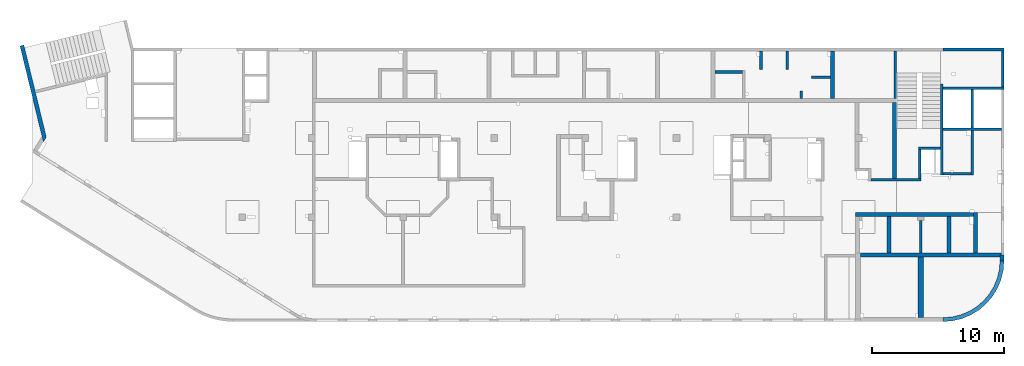
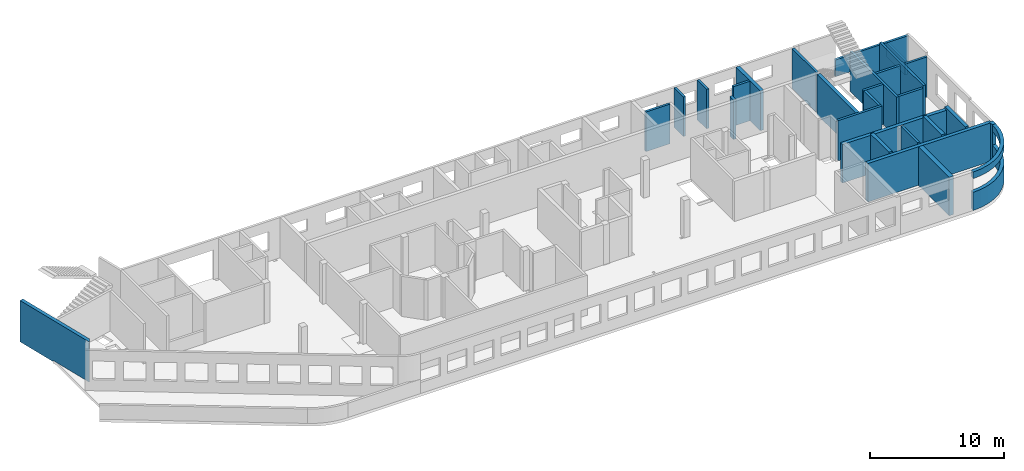
# One storey, part 5 of 10: 29 walls.
"""IFC4 building model written with IfcOpenShell, lengths in millimetres."""

from ifc_helpers import new_model, entity, si_unit, converted_unit, derived_unit, direction, frame, origin, place, context, subcontext, project, spatial, indexed_curve, outline, extrude, polygons, material, type_object, element, save


model = new_model("IFC4")

# Units and contexts
model_context = context("Model", 3, precision=0.01, world=origin(), true_north=direction((6.12303176911189e-17, 1.0)))
plan_context = context("Plan", 3, precision=0.01, world=origin(), true_north=direction((6.12303176911189e-17, 1.0)))
body_context = subcontext(model_context, "Body", "Model", "MODEL_VIEW")
ifc_project = project(units=[si_unit("LENGTHUNIT", "METRE", prefix="MILLI"), si_unit("AREAUNIT", "SQUARE_METRE"), si_unit("VOLUMEUNIT", "CUBIC_METRE"), converted_unit("PLANEANGLEUNIT", "DEGREE", entity("IfcRatioMeasure", 0.0174532925199433), si_unit("PLANEANGLEUNIT", "RADIAN"), dimensions=[0, 0, 0, 0, 0, 0, 0]), si_unit("MASSUNIT", "GRAM", prefix="KILO"), derived_unit("MASSDENSITYUNIT", [(si_unit("MASSUNIT", "GRAM", prefix="KILO"), 1), (si_unit("LENGTHUNIT", "METRE"), -3)]), derived_unit("MOMENTOFINERTIAUNIT", [(si_unit("LENGTHUNIT", "METRE"), 4)]), si_unit("TIMEUNIT", "SECOND"), si_unit("FREQUENCYUNIT", "HERTZ"), si_unit("THERMODYNAMICTEMPERATUREUNIT", "DEGREE_CELSIUS"), derived_unit("THERMALTRANSMITTANCEUNIT", [(si_unit("MASSUNIT", "GRAM", prefix="KILO"), 1), (si_unit("THERMODYNAMICTEMPERATUREUNIT", "KELVIN"), -1), (si_unit("TIMEUNIT", "SECOND"), -3)]), derived_unit("VOLUMETRICFLOWRATEUNIT", [(si_unit("LENGTHUNIT", "METRE"), 3), (si_unit("TIMEUNIT", "SECOND"), -1)]), derived_unit("MASSFLOWRATEUNIT", [(si_unit("MASSUNIT", "GRAM", prefix="KILO"), 1), (si_unit("TIMEUNIT", "SECOND"), -1)]), derived_unit("ROTATIONALFREQUENCYUNIT", [(si_unit("TIMEUNIT", "SECOND"), -1)]), si_unit("ELECTRICCURRENTUNIT", "AMPERE"), si_unit("ELECTRICVOLTAGEUNIT", "VOLT"), si_unit("POWERUNIT", "WATT"), si_unit("FORCEUNIT", "NEWTON", prefix="KILO"), si_unit("ILLUMINANCEUNIT", "LUX"), si_unit("LUMINOUSFLUXUNIT", "LUMEN"), si_unit("LUMINOUSINTENSITYUNIT", "CANDELA"), derived_unit("USERDEFINED", [(si_unit("MASSUNIT", "GRAM", prefix="KILO"), -1), (si_unit("LENGTHUNIT", "METRE"), -2), (si_unit("TIMEUNIT", "SECOND"), 3), (si_unit("LUMINOUSFLUXUNIT", "LUMEN"), 1)]), derived_unit("LINEARVELOCITYUNIT", [(si_unit("LENGTHUNIT", "METRE"), 1), (si_unit("TIMEUNIT", "SECOND"), -1)]), si_unit("PRESSUREUNIT", "PASCAL"), derived_unit("USERDEFINED", [(si_unit("LENGTHUNIT", "METRE"), -2), (si_unit("MASSUNIT", "GRAM", prefix="KILO"), 1), (si_unit("TIMEUNIT", "SECOND"), -2)]), derived_unit("LINEARFORCEUNIT", [(si_unit("MASSUNIT", "GRAM", prefix="KILO"), 1), (si_unit("LENGTHUNIT", "METRE"), 1), (si_unit("TIMEUNIT", "SECOND"), -2), (si_unit("LENGTHUNIT", "METRE"), -1)]), derived_unit("PLANARFORCEUNIT", [(si_unit("MASSUNIT", "GRAM", prefix="KILO"), 1), (si_unit("LENGTHUNIT", "METRE"), 1), (si_unit("TIMEUNIT", "SECOND"), -2), (si_unit("LENGTHUNIT", "METRE"), -2)])], contexts=[model_context, plan_context])

# Site, building, storey
site_placement = place(None, origin())
site = spatial("IfcSite", under=ifc_project, at=site_placement, CompositionType="ELEMENT")
building_placement = place(site_placement, origin())
building = spatial("IfcBuilding", under=site, at=building_placement, CompositionType="ELEMENT")
storey_placement = place(building_placement, frame((0.0, 0.0, 4200.0)))
storey = spatial("IfcBuildingStorey", under=building, at=storey_placement, Name="02", CompositionType="ELEMENT", Elevation=4200.0)

# Walls
ifc_material = material()
wall_type_1 = type_object("IfcWallType", Name=":ADSK_ 25_200", PredefinedType="STANDARD")
wall_1_placement = place(storey_placement, frame((55170.0, 20300.0, -150.0), z_axis=(0.0, 0.0, 1.0), x_axis=(0.0, -1.0, 0.0)))
element("IfcWall", 1, at=wall_1_placement, inside=storey, type_object=wall_type_1, material=ifc_material, Name=":ADSK_ 25_200", ObjectType=":ADSK_ 25_200", PredefinedType="NOTDEFINED", context=body_context, shape_type="SweptSolid", body=[
    extrude(outline(indexed_curve([(1400.00000000018, 100.000000000003), (0.0, 100.000000000003), (0.0, -100.000000000003), (1400.00000000018, -100.000000000003), (1400.00000000018, 100.000000000003)], self_intersect=False)), origin(), (0.0, 0.0, 1.0), 3600.0),
])
wall_2_placement = place(storey_placement, frame((57170.0, 20300.0, -150.0), z_axis=(0.0, 0.0, 1.0), x_axis=(0.0, -1.0, 0.0)))
element("IfcWall", 2, at=wall_2_placement, inside=storey, type_object=wall_type_1, material=ifc_material, Name=":ADSK_ 25_200", ObjectType=":ADSK_ 25_200", PredefinedType="NOTDEFINED", context=body_context, shape_type="SweptSolid", body=[
    extrude(outline(indexed_curve([(1400.00000000017, 100.000000000003), (0.0, 100.000000000003), (0.0, -100.000000000003), (1400.00000000017, -100.000000000003), (1400.00000000017, 100.000000000003)], self_intersect=False)), origin(), (0.0, 0.0, 1.0), 3600.0),
])
wall_3_placement = place(storey_placement, frame((53770.0, 18700.0, -150.0), z_axis=(0.0, 0.0, 1.0), x_axis=(-1.0, 0.0, 0.0)))
element("IfcWall", 3, at=wall_3_placement, inside=storey, type_object=wall_type_1, material=ifc_material, Name=":ADSK_ 25_200", ObjectType=":ADSK_ 25_200", PredefinedType="NOTDEFINED", context=body_context, shape_type="SweptSolid", body=[
    extrude(outline(indexed_curve([(2079.99999999999, 99.9999999999984), (-2.84965034025891e-13, 99.9999999999989), (2.84965034025891e-13, -99.9999999999989), (2080.0, -99.9999999999995), (2079.99999999999, 99.9999999999984)], self_intersect=False)), origin(), (0.0, 0.0, 1.0), 3600.0),
])
wall_4_placement = place(storey_placement, frame((58220.0, 16700.0, -150.0), z_axis=(0.0, 0.0, 1.0), x_axis=(0.0, 1.0, 0.0)))
element("IfcWall", 4, at=wall_4_placement, inside=storey, type_object=wall_type_1, material=ifc_material, Name=":ADSK_ 25_200", ObjectType=":ADSK_ 25_200", PredefinedType="NOTDEFINED", context=body_context, shape_type="SweptSolid", body=[
    extrude(outline(indexed_curve([(550.000000000001, 100.000000000003), (0.0, 100.000000000003), (0.0, -100.000000000003), (550.000000000001, -100.000000000003), (550.000000000001, 100.000000000003)], self_intersect=False)), origin(), (0.0, 0.0, 1.0), 3600.0),
])
wall_5_placement = place(storey_placement, frame((60420.0, 18300.0, -150.0), z_axis=(0.0, 0.0, 1.0), x_axis=(-1.0, 0.0, 0.0)))
element("IfcWall", 5, at=wall_5_placement, inside=storey, type_object=wall_type_1, material=ifc_material, Name=":ADSK_ 25_200", ObjectType=":ADSK_ 25_200", PredefinedType="NOTDEFINED", context=body_context, shape_type="SweptSolid", body=[
    extrude(outline(indexed_curve([(1430.0, 99.9999999999994), (-3.38034999930937e-13, 99.9999999999989), (3.38034999930937e-13, -99.9999999999989), (1430.0, -99.9999999999984), (1430.0, 99.9999999999994)], self_intersect=False)), origin(), (0.0, 0.0, 1.0), 3600.0),
])
wall_6_placement = place(storey_placement, frame((65330.0, 16700.0, -150.0), z_axis=(0.0, 0.0, 1.0), x_axis=(0.0, 1.0, 0.0)))
element("IfcWall", 6, at=wall_6_placement, inside=storey, type_object=wall_type_1, material=ifc_material, Name=":ADSK_ 25_200", ObjectType=":ADSK_ 25_200", PredefinedType="NOTDEFINED", context=body_context, shape_type="SweptSolid", body=[
    extrude(outline(indexed_curve([(3600.00000000025, 100.000000000003), (-2.40637139844095e-13, 100.000000000003), (2.40637139844095e-13, -100.000000000003), (3600.00000000025, -100.000000000003), (3600.00000000025, 100.000000000003)], self_intersect=False)), origin(), (0.0, 0.0, 1.0), 3600.0),
])
wall_7_placement = place(storey_placement, frame((68870.0, 17780.0, -150.0), z_axis=(0.0, 0.0, 1.0), x_axis=(0.0, -1.0, 0.0)))
element("IfcWall", 7, at=wall_7_placement, inside=storey, type_object=wall_type_1, material=ifc_material, Name=":ADSK_ 25_200", ObjectType=":ADSK_ 25_200", PredefinedType="NOTDEFINED", context=body_context, shape_type="SweptSolid", body=[
    extrude(outline(indexed_curve([(6894.9999999995, 100.000000000003), (0.0, 100.000000000003), (0.0, -100.000000000003), (6894.9999999995, -100.000000000003), (6894.9999999995, 100.000000000003)], self_intersect=False)), origin(), (0.0, 0.0, 1.0), 3650.0),
])
wall_8_placement = place(storey_placement, frame((68970.0, 17470.0, -150.0)))
element("IfcWall", 8, at=wall_8_placement, inside=storey, type_object=wall_type_1, material=ifc_material, Name=":ADSK_ 25_200", ObjectType=":ADSK_ 25_200", PredefinedType="NOTDEFINED", context=body_context, shape_type="SweptSolid", body=[
    extrude(outline(indexed_curve([(4600.00000000001, 99.999999999999), (-3.30820688860804e-13, 99.9999999999989), (3.30820688860804e-13, -99.9999999999989), (4600.00000000001, -99.9999999999989), (4600.00000000001, 99.999999999999)], self_intersect=False)), origin(), (0.0, 0.0, 1.0), 3650.0),
])
wall_9_placement = place(storey_placement, frame((73370.0, 14370.0, -150.0), z_axis=(0.0, 0.0, 1.0), x_axis=(-1.0, 0.0, 0.0)))
element("IfcWall", 9, at=wall_9_placement, inside=storey, type_object=wall_type_1, material=ifc_material, Name=":ADSK_ 25_200", ObjectType=":ADSK_ 25_200", PredefinedType="NOTDEFINED", context=body_context, shape_type="SweptSolid", body=[
    extrude(outline(indexed_curve([(4400.0, 99.9999999999989), (-3.44548632049484e-13, 99.9999999999989), (3.44548632049484e-13, -99.9999999999989), (4400.00000000001, -99.9999999999989), (4400.0, 99.9999999999989)], self_intersect=False)), origin(), (0.0, 0.0, 1.0), 3650.0),
])
wall_10_placement = place(storey_placement, frame((71170.0, 17370.0, -150.0), z_axis=(0.0, 0.0, 1.0), x_axis=(0.0, -1.0, 0.0)))
element("IfcWall", 10, at=wall_10_placement, inside=storey, type_object=wall_type_1, material=ifc_material, Name=":ADSK_ 25_200", ObjectType=":ADSK_ 25_200", PredefinedType="NOTDEFINED", context=body_context, shape_type="Tessellation", body=[
    polygons([(6484.99999999949, -99.9999999999925, 3900.0), (0.0, -99.9999999999945, 3900.0), (0.0, -99.9999999999945, 5.41433564649196e-13), (2899.9999999995, -100.000000000003, 5.41433564649196e-13), (2899.9999999995, -100.000000000003, 3650.0), (3099.9999999995, -100.000000000003, 3650.0), (3099.9999999995, -100.000000000003, 5.41433564649196e-13), (6284.99999999949, -99.9999999999931, 5.41433564649196e-13), (6484.99999999949, -99.9999999999925, 5.41433564649196e-13), (6484.99999999949, -99.9999999999925, 3650.0), (0.0, 100.000000000003, 3900.0), (6484.99999999949, 100.000000000014, 3900.0), (6484.99999999949, 100.000000000014, 5.41433564649196e-13), (3099.9999999995, 100.000000000004, 5.41433564649196e-13), (3099.9999999995, 100.000000000004, 3650.0), (2899.9999999995, 100.000000000003, 3650.0), (2899.9999999995, 100.000000000003, 5.41433564649196e-13), (0.0, 100.000000000003, 5.41433564649196e-13), (0.0, -0.000817871099276511, 3900.0)], [[[1, 2, 3, 4, 5, 6, 7, 8, 9, 10]], [[11, 12, 13, 14, 15, 16, 17, 18]], [[3, 18, 17, 4]], [[2, 1, 12, 11, 19]], [[16, 5, 4, 17]], [[6, 15, 14, 7]], [[5, 16, 15, 6]], [[1, 10, 9, 13, 12]], [[2, 19, 11, 18, 3]], [[13, 9, 8, 7, 14]]], closed=True),
])
wall_11_placement = place(storey_placement, frame((63485.0, 10525.0, -150.0)))
element("IfcWall", 11, at=wall_11_placement, inside=storey, type_object=wall_type_1, material=ifc_material, Name=":ADSK_ 25_200", ObjectType=":ADSK_ 25_200", PredefinedType="NOTDEFINED", context=body_context, shape_type="SweptSolid", body=[
    extrude(outline(indexed_curve([(3795.0, 99.9999999999989), (0.0, 99.9999999999989), (0.0, -99.9999999999989), (3795.0, -99.9999999999989), (3795.0, 99.9999999999989)], self_intersect=False)), origin(), (0.0, 0.0, 1.0), 3650.0),
])
wall_12_placement = place(storey_placement, frame((71070.0, 10985.0, -150.0), z_axis=(0.0, 0.0, 1.0), x_axis=(-1.0, 0.0, 0.0)))
element("IfcWall", 12, at=wall_12_placement, inside=storey, type_object=wall_type_1, material=ifc_material, Name=":ADSK_ 25_200", ObjectType=":ADSK_ 25_200", PredefinedType="NOTDEFINED", context=body_context, shape_type="SweptSolid", body=[
    extrude(outline(indexed_curve([(2099.99999999999, 99.9999999999989), (0.0, 99.9999999999989), (0.0, -99.9999999999989), (2099.99999999999, -99.9999999999989), (2099.99999999999, 99.9999999999989)], self_intersect=False)), origin(), (0.0, 0.0, 1.0), 3650.0),
])
wall_13_placement = place(storey_placement, frame((68770.0, 12930.0, -150.0), z_axis=(0.0, 0.0, 1.0), x_axis=(-1.0, 0.0, 0.0)))
element("IfcWall", 13, at=wall_13_placement, inside=storey, type_object=wall_type_1, material=ifc_material, Name=":ADSK_ 25_200", ObjectType=":ADSK_ 25_200", PredefinedType="NOTDEFINED", context=body_context, shape_type="SweptSolid", body=[
    extrude(outline(indexed_curve([(1690.00000000001, 100.000000000003), (-3.40554850242062e-13, 100.000000000001), (3.40554850242062e-13, -100.000000000001), (1690.00000000001, -99.9999999999997), (1690.00000000001, 100.000000000003)], self_intersect=False)), origin(), (0.0, 0.0, 1.0), 3650.0),
])
wall_14_placement = place(storey_placement, frame((67180.0, 12830.0, -150.0), z_axis=(0.0, 0.0, 1.0), x_axis=(0.0, -1.0, 0.0)))
element("IfcWall", 14, at=wall_14_placement, inside=storey, type_object=wall_type_1, material=ifc_material, Name=":ADSK_ 25_200", ObjectType=":ADSK_ 25_200", PredefinedType="NOTDEFINED", context=body_context, shape_type="SweptSolid", body=[
    extrude(outline(indexed_curve([(2204.99922635597, 100.000000000003), (0.0, 100.000000000003), (0.0, -100.000000000003), (2204.99922635597, -100.000000000003), (2204.99922635597, 100.000000000003)], self_intersect=False)), origin(), (0.0, 0.0, 1.0), 3650.0),
])
wall_15_placement = place(storey_placement, frame((67270.0, 4975.0, -150.0), z_axis=(0.0, 0.0, 1.0), x_axis=(0.0, 1.0, 0.0)))
element("IfcWall", 15, at=wall_15_placement, inside=storey, type_object=wall_type_1, material=ifc_material, Name=":ADSK_ 25_200", ObjectType=":ADSK_ 25_200", PredefinedType="NOTDEFINED", context=body_context, shape_type="SweptSolid", body=[
    extrude(outline(indexed_curve([(2475.00000000007, 100.000000000003), (0.0, 100.000000000003), (0.0, -100.000000000003), (2475.00000000007, -100.000000000003), (2475.00000000007, 100.000000000003)], self_intersect=False)), origin(), (0.0, 0.0, 1.0), 3650.0),
])
wall_16_placement = place(storey_placement, frame((68970.0, 20400.0, -420.0)))
element("IfcWall", 16, at=wall_16_placement, inside=storey, type_object=wall_type_1, material=ifc_material, Name=":ADSK_ 25_200", ObjectType=":ADSK_ 25_200", PredefinedType="NOTDEFINED", context=body_context, shape_type="SweptSolid", body=[
    extrude(outline(indexed_curve([(4600.0, 99.9999999999992), (-3.82188398575899e-13, 99.9999999999989), (3.82188398575899e-13, -99.9999999999989), (4600.0, -99.9999999999987), (4600.0, 99.9999999999992)], self_intersect=False)), origin(), (0.0, 0.0, 1.0), 1520.0),
])
wall_17_placement = place(storey_placement, frame((73470.0, 17570.0, -150.0), z_axis=(0.0, 0.0, 1.0), x_axis=(0.0, 1.0, 0.0)))
element("IfcWall", 17, at=wall_17_placement, inside=storey, type_object=wall_type_1, material=ifc_material, Name=":ADSK_ 25_200", ObjectType=":ADSK_ 25_200", PredefinedType="NOTDEFINED", context=body_context, shape_type="SweptSolid", body=[
    extrude(outline(indexed_curve([(2730.0000000005, 100.000000000003), (0.0, 100.000000000003), (0.0, -100.000000000003), (2730.0000000005, -100.000000000003), (2730.0000000005, 100.000000000003)], self_intersect=False)), origin(), (0.0, 0.0, 1.0), 1250.0),
])
wall_type_2 = type_object("IfcWallType", Name=":ADSK_ 25_300", PredefinedType="STANDARD")
wall_18_placement = place(storey_placement, frame((-787.54, 20703.3, -250.0), z_axis=(0.0, 0.0, 1.0), x_axis=(0.236826092990336, -0.971552058141473, 0.0)))
element("IfcWall", 18, at=wall_18_placement, inside=storey, type_object=wall_type_2, material=ifc_material, Name=":ADSK_ 25_300", ObjectType=":ADSK_ 25_300", PredefinedType="NOTDEFINED", context=body_context, shape_type="Tessellation", body=[
    polygons([(7469.92693582263, -149.999999999999, 3750.0), (7050.74397411926, -149.999999999999, 3750.0), (7050.16407046701, -149.999999999999, 3750.0), (3540.00000000002, -149.999999999999, 3750.0), (4.33146851719357e-12, -149.999999999999, 3750.0), (4.33146851719357e-12, -149.999999999999, -5.41433564649196e-13), (3540.00000000002, -149.999999999999, -5.41433564649196e-13), (3540.00000000002, -149.999999999998, 99.9999999999995), (3940.77040872538, -149.999999999999, 99.9999999999995), (7050.74397411926, -149.999999999999, 99.9999999999995), (7469.36266127936, -149.999999999999, 99.9999999999995), (7469.36266127936, -149.999999999998, -5.41433564649196e-13), (7469.92693582263, -149.999999999999, -5.41433564649196e-13), (7469.92693582263, -149.999999999999, 99.9999999999995), (0.0, 150.000000000001, -5.41433564649196e-13), (0.0, 150.000000000001, 3250.0), (0.0, 150.000000000001, 3750.0), (200.000000000037, 150.000000000001, 3750.0), (3540.00000000001, 150.000000000001, 3750.0), (3740.0, 150.000000000001, 3750.0), (6757.3939296015, 150.000000000001, 3750.0), (7177.15679495713, 150.000000000001, 3750.0), (7177.15679495713, 150.000000000002, 99.9999999999995), (3740.00000000001, 150.000000000001, 99.9999999999995), (3540.00000000002, 150.000000000002, 99.9999999999995), (3540.00000000002, 150.000000000001, -5.41433564649196e-13), (7467.45995599307, -147.472098941924, -5.41433564649196e-13), (7467.45995599307, -147.472098941924, 99.9999999999995), (7467.17093496546, -147.754149749605, 99.9999999999995), (7467.17093496546, -147.754149749605, -5.41433564649196e-13)], [[[1, 2, 3, 4, 5, 6, 7, 8, 9, 10, 11, 12, 13, 14]], [[15, 16, 17, 18, 19, 20, 21, 22, 23, 24, 25, 26]], [[6, 15, 26, 7]], [[5, 4, 3, 2, 1, 22, 21, 20, 19, 18, 17]], [[6, 5, 17, 16, 15]], [[1, 14, 13, 27, 28, 23, 22]], [[8, 25, 24, 23, 28, 29, 11, 10, 9]], [[25, 8, 7, 26]], [[29, 28, 27, 30]], [[11, 29, 30, 12]], [[13, 12, 30, 27]]], closed=True),
])
wall_19_placement = place(storey_placement, frame((60570.0, 20300.0, -150.0), z_axis=(0.0, 0.0, 1.0), x_axis=(0.0, -1.0, 0.0)))
element("IfcWall", 19, at=wall_19_placement, inside=storey, type_object=wall_type_2, material=ifc_material, Name=":ADSK_ 25_300", ObjectType=":ADSK_ 25_300", PredefinedType="NOTDEFINED", context=body_context, shape_type="SweptSolid", body=[
    extrude(outline(indexed_curve([(3600.00000000024, 150.0), (-3.33189885937964e-13, 150.000000000001), (3.33189885937964e-13, -150.000000000001), (3600.00000000024, -150.000000000001), (3600.00000000024, 150.0)], self_intersect=False)), origin(), (0.0, 0.0, 1.0), 3600.0),
])
wall_20_placement = place(storey_placement, frame((65280.0, 10625.0, -150.0), z_axis=(0.0, 0.0, 1.0), x_axis=(0.0, 1.0, 0.0)))
element("IfcWall", 20, at=wall_20_placement, inside=storey, type_object=wall_type_2, material=ifc_material, Name=":ADSK_ 25_300", ObjectType=":ADSK_ 25_300", PredefinedType="NOTDEFINED", context=body_context, shape_type="SweptSolid", body=[
    extrude(outline(indexed_curve([(5774.99922635596, 150.000000000001), (-2.2868418396868e-13, 150.000000000001), (2.2868418396868e-13, -150.000000000001), (5774.99922635596, -150.0), (5774.99922635596, 150.000000000001)], self_intersect=False)), origin(), (0.0, 0.0, 1.0), 3650.0),
])
wall_21_placement = place(storey_placement, frame((62720.0, 4825.0, -150.0)))
element("IfcWall", 21, at=wall_21_placement, inside=storey, type_object=wall_type_2, material=ifc_material, Name=":ADSK_ 25_300", ObjectType=":ADSK_ 25_300", PredefinedType="NOTDEFINED", context=body_context, shape_type="SweptSolid", body=[
    extrude(outline(indexed_curve([(10550.0, -150.0), (10550.0, -6.0596314870462e-13), (10650.0, -2.8325428625114e-13), (10650.0, 150.0), (8855.0, 150.0), (8555.0, 150.0), (6830.0, 150.0), (6530.0, 150.0), (4649.99999999999, 150.0), (4449.99999999999, 150.0), (2289.99999999999, 150.0), (1989.99999999999, 150.0), (-4.84063293680244e-13, 149.999999999999), (4.84063293680246e-13, -150.0), (4350.0, -150.0), (4749.99999999999, -150.0), (10550.0, -150.0)], self_intersect=False)), origin(), (0.0, 0.0, 1.0), 3500.0),
])
wall_22_placement = place(storey_placement, frame((73420.0, 4825.0, -150.0), z_axis=(0.0, 0.0, 1.0), x_axis=(0.0, -1.0, 0.0)))
element("IfcWall", 22, at=wall_22_placement, inside=storey, type_object=wall_type_2, material=ifc_material, Name=":ADSK_ 25_300", ObjectType=":ADSK_ 25_300", PredefinedType="NOTDEFINED", context=body_context, shape_type="Tessellation", body=[
    polygons([(0.0, -150.000000000001, 5.41433564649196e-13), (149.999999999999, -150.000000000001, 5.41433564649196e-13), (424.995930143775, -150.000000000001, 5.41433564649196e-13), (424.995930143776, -150.000000000001, 1650.0), (424.995930143776, -150.000000000001, 2900.0), (424.995930143775, -150.000000000001, 3500.0), (149.999999999999, -150.000000000001, 3500.0), (0.0, -150.000000000001, 3500.0), (424.995930143775, 150.000000000001, 5.41433564649196e-13), (0.0, 150.000000000001, 5.41433564649196e-13), (0.0, 150.000000000001, 3500.0), (424.995930143775, 150.000000000001, 3500.0), (424.995930143776, 150.000000000001, 2900.0), (424.995930143776, 150.000000000001, 1650.0), (0.0, -49.9999999999973, 5.41433564649196e-13), (0.0, -49.9999999999973, 3500.0)], [[[1, 2, 3, 4, 5, 6, 7, 8]], [[9, 10, 11, 12, 13, 14]], [[3, 2, 1, 15, 10, 9]], [[3, 9, 14, 13, 12, 6, 5, 4]], [[10, 15, 1, 8, 16, 11]], [[8, 7, 6, 12, 11, 16]]], closed=True),
])
wall_23_placement = place(storey_placement, frame((73420.0, 4400.0, -150.0)))
element("IfcWall", 23, at=wall_23_placement, inside=storey, type_object=wall_type_2, material=ifc_material, Name=":ADSK_ 25_300", ObjectType=":ADSK_ 25_300", PredefinedType="NOTDEFINED", context=body_context, shape_type="SweptSolid", body=[
    extrude(outline(indexed_curve([(-4450.0040698544, -4600.00406985442), (-3730.40489400384, -4543.3703864854), (-3028.52463807546, -4374.86384561929), (-2361.64592337724, -4098.63363753335), (-1746.18951710861, -3721.48146670617), (-1197.30999857462, -3252.6940712798), (-728.52260314825, -2703.81455274581), (-351.370432321072, -2088.35814647718), (-75.1402242351338, -1421.47943177896), (93.3663166309807, -719.599175850587), (150.000000000001, -2.65302446678106e-11), (-150.000000000001, -2.70716782324598e-12), (-202.940185547554, -672.668836338494), (-360.457179123676, -1328.77433346646), (-618.672389577566, -1952.16099655529), (-971.227701460713, -2527.47897705804), (-1409.44203293056, -3040.56203692382), (-1922.52509279633, -3478.77636839367), (-2497.84307329908, -3831.33168027683), (-3121.22973638791, -4089.54689073073), (-3777.33523351588, -4247.06388430685), (-4450.00406985436, -4300.00406985442), (-4450.0040698544, -4600.00406985442)], self_intersect=False)), origin(), (0.0, 0.0, 1.0), 1650.0),
])
wall_24_placement = place(storey_placement, frame((73420.0, 4400.0, 2750.0)))
element("IfcWall", 24, at=wall_24_placement, inside=storey, type_object=wall_type_2, material=ifc_material, Name=":ADSK_ 25_300", ObjectType=":ADSK_ 25_300", PredefinedType="NOTDEFINED", context=body_context, shape_type="SweptSolid", body=[
    extrude(outline(indexed_curve([(-4450.0040698544, -4600.00406985442), (-3730.40489400384, -4543.3703864854), (-3028.52463807546, -4374.86384561929), (-2361.64592337724, -4098.63363753335), (-1746.18951710861, -3721.48146670617), (-1197.30999857462, -3252.6940712798), (-728.52260314825, -2703.81455274581), (-351.370432321072, -2088.35814647718), (-75.1402242351338, -1421.47943177896), (93.3663166309807, -719.599175850587), (150.000000000001, -2.65302446678106e-11), (-150.000000000001, -2.70716782324598e-12), (-202.940185547554, -672.668836338494), (-360.457179123676, -1328.77433346646), (-618.672389577566, -1952.16099655529), (-971.227701460713, -2527.47897705804), (-1409.44203293056, -3040.56203692382), (-1922.52509279633, -3478.77636839367), (-2497.84307329908, -3831.33168027683), (-3121.22973638791, -4089.54689073073), (-3777.33523351588, -4247.06388430685), (-4450.00406985436, -4300.00406985442), (-4450.0040698544, -4600.00406985442)], self_intersect=False)), origin(), (0.0, 0.0, 1.0), 600.0),
])
wall_25_placement = place(storey_placement, frame((71425.0, 4975.0, -150.0), z_axis=(0.0, 0.0, 1.0), x_axis=(0.0, 1.0, 0.0)))
element("IfcWall", 25, at=wall_25_placement, inside=storey, type_object=wall_type_2, material=ifc_material, Name=":ADSK_ 25_300", ObjectType=":ADSK_ 25_300", PredefinedType="NOTDEFINED", context=body_context, shape_type="SweptSolid", body=[
    extrude(outline(indexed_curve([(3074.99999999989, 150.000000000001), (0.0, 150.000000000001), (0.0, -150.000000000001), (3074.99999999989, -150.000000000001), (3074.99999999989, 150.000000000001)], self_intersect=False)), origin(), (0.0, 0.0, 1.0), 3650.0),
])
for number, where, z_axis, x_axis, name in (
    (26, (64860.0, 4975.0, -150.0), (0.0, 0.0, 1.0), (0.0, 1.0, 0.0), ":ADSK_ 25_300"),
    (27, (69400.0, 4975.0, -150.0), (0.0, 0.0, 1.0), (0.0, 1.0, 0.0), ":ADSK_ 25_300"),
):
    element("IfcWall", number, at=place(storey_placement, frame(where, z_axis=z_axis, x_axis=x_axis)), inside=storey, type_object=wall_type_2, material=ifc_material, Name=name, ObjectType=":ADSK_ 25_300", PredefinedType="NOTDEFINED", context=body_context, shape_type="SweptSolid", body=[
        extrude(outline(indexed_curve([(2774.99999999989, 150.000000000001), (0.0, 150.000000000001), (0.0, -150.000000000001), (2774.99999999989, -150.000000000001), (2774.99999999989, 150.000000000001)], self_intersect=False)), origin(), (0.0, 0.0, 1.0), 3650.0),
    ])
wall_26_placement = place(storey_placement, frame((62320.0, 7900.0, -150.0)))
element("IfcWall", 28, at=wall_26_placement, inside=storey, type_object=wall_type_2, material=ifc_material, Name=":ADSK_ 25_300", ObjectType=":ADSK_ 25_300", PredefinedType="NOTDEFINED", context=body_context, shape_type="SweptSolid", body=[
    extrude(outline(indexed_curve([(8955.0, 149.999999999999), (-4.3498925243293e-13, 149.999999999999), (4.3498925243293e-13, -149.999999999999), (8955.0, -149.999999999999), (8955.0, 149.999999999999)], self_intersect=False)), origin(), (0.0, 0.0, 1.0), 3500.0),
])
wall_type_3 = type_object("IfcWallType", Name=":ADSK_ 25_400", PredefinedType="STANDARD")
wall_27_placement = place(storey_placement, frame((67270.0, 100.0, -150.0), z_axis=(0.0, 0.0, 1.0), x_axis=(0.0, 1.0, 0.0)))
element("IfcWall", 29, at=wall_27_placement, inside=storey, type_object=wall_type_3, material=ifc_material, Name=":ADSK_ 25_400", ObjectType=":ADSK_ 25_400", PredefinedType="NOTDEFINED", context=body_context, shape_type="Tessellation", body=[
    polygons([(1.69197988952874e-14, -199.999999999998, 5.41433564649196e-13), (4575.0, -199.999999999998, 5.41433564649196e-13), (4575.0, -199.999999999998, 3500.0), (1.52278190057586e-13, -199.999999999998, 3500.0), (4575.0, 199.999999999998, 5.41433564649196e-13), (300.000000000367, 199.999999999999, 5.41433564649196e-13), (5.41433564649196e-13, 199.999999999989, 5.41433564649196e-13), (5.41433564649196e-13, 199.999999999989, 3500.0), (300.001042198784, 199.999999999999, 3500.0), (4575.0, 199.999999999998, 3500.0)], [[[1, 2, 3, 4]], [[5, 6, 7, 8, 9, 10]], [[2, 1, 7, 6, 5]], [[2, 5, 10, 3]], [[7, 1, 4, 8]], [[4, 3, 10, 9, 8]]], closed=True),
])

save(model, "model.ifc")
